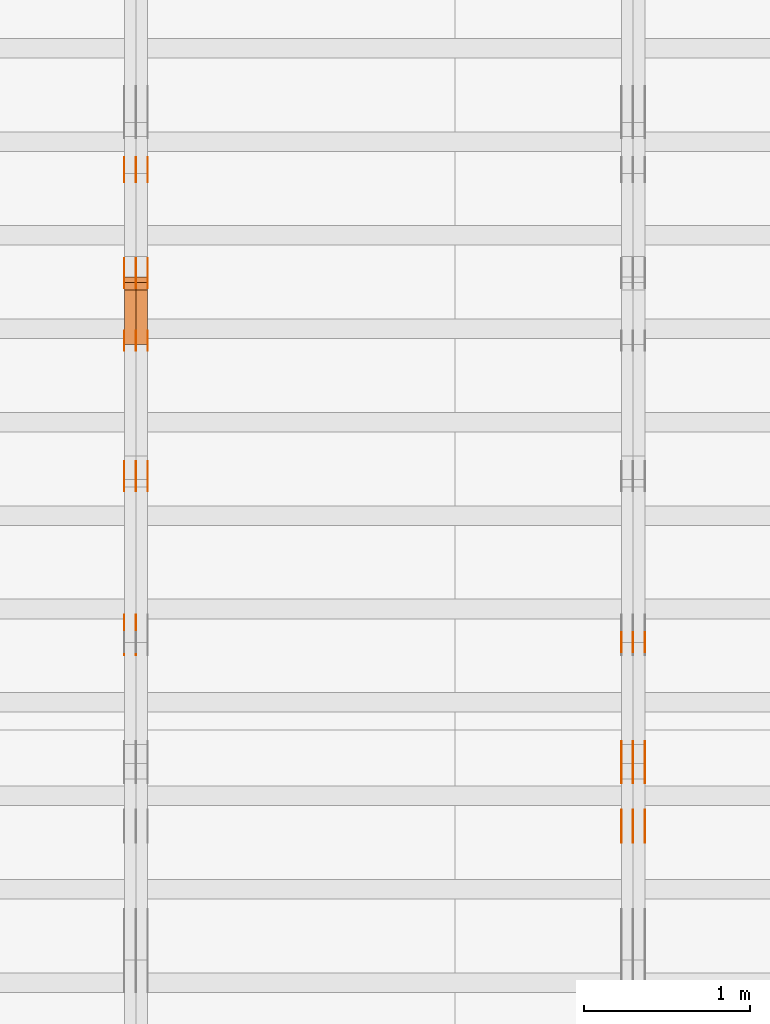
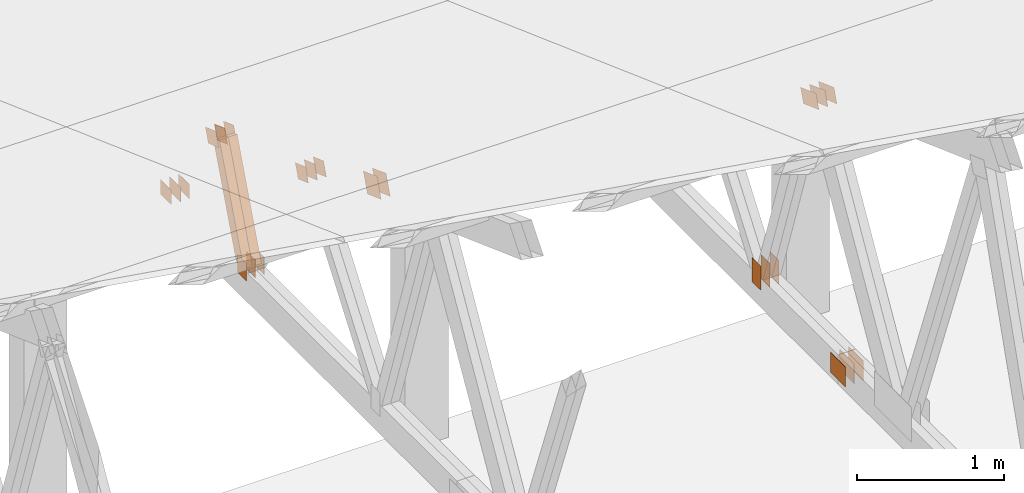
# One storey, part 131 of 189: 32 proxies.
"""IFC2X3 building model written with IfcOpenShell, lengths in millimetres."""

from ifc_helpers import new_model, entity, si_unit, converted_unit, derived_unit, direction, frame, frame_2d, origin, origin_2d_with_axis, place, context, subcontext, project, spatial, polyline, rectangle, outline, extrude, source, transform, mapped, material, type_object, type_shapes, element, save


model = new_model("IFC2X3")

# Units and contexts
model_context = context("Model", 3, precision=0.01, world=origin(), true_north=direction((6.12303176911189e-17, 1.0)))
body_context = subcontext(model_context, "Body", "Model", "MODEL_VIEW")
ifc_project = project(units=[si_unit("LENGTHUNIT", "METRE", prefix="MILLI"), si_unit("AREAUNIT", "SQUARE_METRE"), si_unit("VOLUMEUNIT", "CUBIC_METRE"), converted_unit("PLANEANGLEUNIT", "DEGREE", entity("IfcRatioMeasure", 0.0174532925199433), si_unit("PLANEANGLEUNIT", "RADIAN"), dimensions=[0, 0, 0, 0, 0, 0, 0]), si_unit("MASSUNIT", "GRAM", prefix="KILO"), derived_unit("MASSDENSITYUNIT", [(si_unit("MASSUNIT", "GRAM", prefix="KILO"), 1), (si_unit("LENGTHUNIT", "METRE"), -3)]), si_unit("TIMEUNIT", "SECOND"), si_unit("FREQUENCYUNIT", "HERTZ"), si_unit("THERMODYNAMICTEMPERATUREUNIT", "DEGREE_CELSIUS"), derived_unit("THERMALTRANSMITTANCEUNIT", [(si_unit("MASSUNIT", "GRAM", prefix="KILO"), 1), (si_unit("THERMODYNAMICTEMPERATUREUNIT", "KELVIN"), -1), (si_unit("TIMEUNIT", "SECOND"), -3)]), derived_unit("VOLUMETRICFLOWRATEUNIT", [(si_unit("LENGTHUNIT", "METRE"), 3), (si_unit("TIMEUNIT", "SECOND"), -1)]), si_unit("ELECTRICCURRENTUNIT", "AMPERE"), si_unit("ELECTRICVOLTAGEUNIT", "VOLT"), si_unit("POWERUNIT", "WATT"), si_unit("FORCEUNIT", "NEWTON"), si_unit("ILLUMINANCEUNIT", "LUX"), si_unit("LUMINOUSFLUXUNIT", "LUMEN"), si_unit("LUMINOUSINTENSITYUNIT", "CANDELA"), derived_unit("USERDEFINED", [(si_unit("MASSUNIT", "GRAM", prefix="KILO"), -1), (si_unit("LENGTHUNIT", "METRE"), -2), (si_unit("TIMEUNIT", "SECOND"), 3), (si_unit("LUMINOUSFLUXUNIT", "LUMEN"), 1)]), derived_unit("LINEARVELOCITYUNIT", [(si_unit("LENGTHUNIT", "METRE"), 1), (si_unit("TIMEUNIT", "SECOND"), -1)]), si_unit("PRESSUREUNIT", "PASCAL"), derived_unit("USERDEFINED", [(si_unit("LENGTHUNIT", "METRE"), -2), (si_unit("MASSUNIT", "GRAM", prefix="KILO"), 1), (si_unit("TIMEUNIT", "SECOND"), -2)])], contexts=[model_context])

# Site, building, storey
site_placement = place(None, origin())
site = spatial("IfcSite", under=ifc_project, at=site_placement, CompositionType="ELEMENT")
building_placement = place(site_placement, origin())
building = spatial("IfcBuilding", under=site, at=building_placement, CompositionType="ELEMENT")
storey_placement = place(building_placement, origin())
storey = spatial("IfcBuildingStorey", under=building, at=storey_placement, Name="Default", CompositionType="ELEMENT", Elevation=0.0)

# Proxies
ifc_material_1 = material(Name="IfcSurfaceStyle #153848")
building_element_proxy_type_1 = type_object("IfcBuildingElementProxyType", PredefinedType="NOTDEFINED", material=ifc_material_1)
shared_shape_1 = source(origin(), body_context, "Body", "SweptSolid", [
    extrude(outline(polyline([(-112.499846801582, -59.999986193028), (112.499924372729, -59.999986193028), (112.499888552087, 59.999986193028), (-112.499966123235, 59.999986193028), (-112.499846801582, -59.999986193028)])), frame((112.499989807712, 60.0001003787081, 0.0), z_axis=(0.0, 0.0, 1.0), x_axis=(-1.0, 0.0, 0.0)), (0.0, 0.0, 1.0), 1.3),
])
type_shapes(building_element_proxy_type_1, [shared_shape_1])
proxy_1_placement = place(building_placement, frame((27301.3, 24040.8868138992, 2049.61031693104), z_axis=(-1.0, 0.0, 0.0), x_axis=(0.0, -0.939692620785908, 0.342020143325669)))
element("IfcBuildingElementProxy", 1, at=proxy_1_placement, inside=storey, type_object=building_element_proxy_type_1, material=ifc_material_1, context=body_context, shape_type="MappedRepresentation", body=[
    mapped(shared_shape_1, transform((0.0, 0.0, 0.0), scale=1.0)),
])
ifc_material_2 = material(Name="IfcSurfaceStyle #153791")
building_element_proxy_type_2 = type_object("IfcBuildingElementProxyType", PredefinedType="NOTDEFINED", material=ifc_material_2)
shared_shape_2 = source(origin(), body_context, "Body", "SweptSolid", [
    extrude(outline(polyline([(-112.499846801582, -59.999986193028), (112.499924372729, -59.999986193028), (112.499888552087, 59.999986193028), (-112.499966123235, 59.999986193028), (-112.499846801582, -59.999986193028)])), frame((112.499989807712, 60.0001003787081, 0.0), z_axis=(0.0, 0.0, 1.0), x_axis=(-1.0, 0.0, 0.0)), (0.0, 0.0, 1.0), 1.29999999999998),
])
type_shapes(building_element_proxy_type_2, [shared_shape_2])
proxy_2_placement = place(building_placement, frame((27230.0, 24040.8868138992, 2049.61031693104), z_axis=(-1.0, 0.0, 0.0), x_axis=(0.0, -0.939692620785908, 0.342020143325669)))
element("IfcBuildingElementProxy", 2, at=proxy_2_placement, inside=storey, type_object=building_element_proxy_type_2, material=ifc_material_2, context=body_context, shape_type="MappedRepresentation", body=[
    mapped(shared_shape_2, transform((0.0, 0.0, 0.0), scale=1.0)),
])
ifc_material_3 = material(Name="IfcSurfaceStyle #153734")
building_element_proxy_type_3 = type_object("IfcBuildingElementProxyType", PredefinedType="NOTDEFINED", material=ifc_material_3)
shared_shape_3 = source(origin(), body_context, "Body", "SweptSolid", [
    extrude(outline(polyline([(-112.499846801582, -59.999986193028), (112.499924372729, -59.999986193028), (112.499888552087, 59.999986193028), (-112.499966123235, 59.999986193028), (-112.499846801582, -59.999986193028)])), frame((112.499989807712, 60.0001003787081, 0.0), z_axis=(0.0, 0.0, 1.0), x_axis=(-1.0, 0.0, 0.0)), (0.0, 0.0, 1.0), 1.29999999999998),
])
type_shapes(building_element_proxy_type_3, [shared_shape_3])
proxy_3_placement = place(building_placement, frame((27231.3, 24040.8868138992, 2049.61031693104), z_axis=(-1.0, 0.0, 0.0), x_axis=(0.0, -0.939692620785908, 0.342020143325669)))
element("IfcBuildingElementProxy", 3, at=proxy_3_placement, inside=storey, type_object=building_element_proxy_type_3, material=ifc_material_3, context=body_context, shape_type="MappedRepresentation", body=[
    mapped(shared_shape_3, transform((0.0, 0.0, 0.0), scale=1.0)),
])
ifc_material_4 = material(Name="IfcSurfaceStyle #153677")
building_element_proxy_type_4 = type_object("IfcBuildingElementProxyType", PredefinedType="NOTDEFINED", material=ifc_material_4)
shared_shape_4 = source(origin(), body_context, "Body", "SweptSolid", [
    extrude(outline(polyline([(-112.499846801582, -59.999986193028), (112.499924372729, -59.999986193028), (112.499888552087, 59.999986193028), (-112.499966123235, 59.999986193028), (-112.499846801582, -59.999986193028)])), frame((112.499989807712, 60.0001003787081, 0.0), z_axis=(0.0, 0.0, 1.0), x_axis=(-1.0, 0.0, 0.0)), (0.0, 0.0, 1.0), 1.29999999999999),
])
type_shapes(building_element_proxy_type_4, [shared_shape_4])
proxy_4_placement = place(building_placement, frame((27160.0, 24040.8868138992, 2049.61031693104), z_axis=(-1.0, 0.0, 0.0), x_axis=(0.0, -0.939692620785908, 0.342020143325669)))
element("IfcBuildingElementProxy", 4, at=proxy_4_placement, inside=storey, type_object=building_element_proxy_type_4, material=ifc_material_4, context=body_context, shape_type="MappedRepresentation", body=[
    mapped(shared_shape_4, transform((0.0, 0.0, 0.0), scale=1.0)),
])
ifc_material_5 = material(Name="IfcSurfaceStyle #153620")
building_element_proxy_type_5 = type_object("IfcBuildingElementProxyType", PredefinedType="NOTDEFINED", material=ifc_material_5)
shared_shape_5 = source(origin(), body_context, "Body", "SweptSolid", [
    extrude(rectangle(XDim=200.0, YDim=120.0, at=origin_2d_with_axis()), frame((100.0, 60.0002296775929, 0.0), z_axis=(0.0, 0.0, 1.0), x_axis=(-1.0, 0.0, 0.0)), (0.0, 0.0, 1.0), 1.3),
])
type_shapes(building_element_proxy_type_5, [shared_shape_5])
proxy_5_placement = place(building_placement, frame((27301.3, 24619.3435203224, 145.0), z_axis=(-1.0, 0.0, 0.0), x_axis=(0.0, 0.0, 1.0)))
element("IfcBuildingElementProxy", 5, at=proxy_5_placement, inside=storey, type_object=building_element_proxy_type_5, material=ifc_material_5, context=body_context, shape_type="MappedRepresentation", body=[
    mapped(shared_shape_5, transform((0.0, 0.0, 0.0), scale=1.0)),
])
ifc_material_6 = material(Name="IfcSurfaceStyle #153563")
building_element_proxy_type_6 = type_object("IfcBuildingElementProxyType", PredefinedType="NOTDEFINED", material=ifc_material_6)
shared_shape_6 = source(origin(), body_context, "Body", "SweptSolid", [
    extrude(rectangle(XDim=200.0, YDim=120.0, at=origin_2d_with_axis()), frame((100.0, 60.0002296775929, 0.0), z_axis=(0.0, 0.0, 1.0), x_axis=(-1.0, 0.0, 0.0)), (0.0, 0.0, 1.0), 1.29999999999998),
])
type_shapes(building_element_proxy_type_6, [shared_shape_6])
proxy_6_placement = place(building_placement, frame((27230.0, 24619.3435203224, 145.0), z_axis=(-1.0, 0.0, 0.0), x_axis=(0.0, 0.0, 1.0)))
element("IfcBuildingElementProxy", 6, at=proxy_6_placement, inside=storey, type_object=building_element_proxy_type_6, material=ifc_material_6, context=body_context, shape_type="MappedRepresentation", body=[
    mapped(shared_shape_6, transform((0.0, 0.0, 0.0), scale=1.0)),
])
ifc_material_7 = material(Name="IfcSurfaceStyle #153506")
building_element_proxy_type_7 = type_object("IfcBuildingElementProxyType", PredefinedType="NOTDEFINED", material=ifc_material_7)
shared_shape_7 = source(origin(), body_context, "Body", "SweptSolid", [
    extrude(rectangle(XDim=200.0, YDim=120.0, at=origin_2d_with_axis()), frame((100.0, 60.0002296775929, 0.0), z_axis=(0.0, 0.0, 1.0), x_axis=(-1.0, 0.0, 0.0)), (0.0, 0.0, 1.0), 1.29999999999998),
])
type_shapes(building_element_proxy_type_7, [shared_shape_7])
proxy_7_placement = place(building_placement, frame((27231.3, 24619.3435203224, 145.0), z_axis=(-1.0, 0.0, 0.0), x_axis=(0.0, 0.0, 1.0)))
element("IfcBuildingElementProxy", 7, at=proxy_7_placement, inside=storey, type_object=building_element_proxy_type_7, material=ifc_material_7, context=body_context, shape_type="MappedRepresentation", body=[
    mapped(shared_shape_7, transform((0.0, 0.0, 0.0), scale=1.0)),
])
ifc_material_8 = material(Name="IfcSurfaceStyle #153449")
building_element_proxy_type_8 = type_object("IfcBuildingElementProxyType", PredefinedType="NOTDEFINED", material=ifc_material_8)
shared_shape_8 = source(origin(), body_context, "Body", "SweptSolid", [
    extrude(rectangle(XDim=200.0, YDim=120.0, at=origin_2d_with_axis()), frame((100.0, 60.0002296775929, 0.0), z_axis=(0.0, 0.0, 1.0), x_axis=(-1.0, 0.0, 0.0)), (0.0, 0.0, 1.0), 1.29999999999999),
])
type_shapes(building_element_proxy_type_8, [shared_shape_8])
proxy_8_placement = place(building_placement, frame((27160.0, 24619.3435203224, 145.0), z_axis=(-1.0, 0.0, 0.0), x_axis=(0.0, 0.0, 1.0)))
element("IfcBuildingElementProxy", 8, at=proxy_8_placement, inside=storey, type_object=building_element_proxy_type_8, material=ifc_material_8, context=body_context, shape_type="MappedRepresentation", body=[
    mapped(shared_shape_8, transform((0.0, 0.0, 0.0), scale=1.0)),
])
ifc_material_9 = material(Name="IfcSurfaceStyle #149972")
building_element_proxy_type_9 = type_object("IfcBuildingElementProxyType", PredefinedType="NOTDEFINED", material=ifc_material_9)
shared_shape_9 = source(origin(), body_context, "Body", "SweptSolid", [
    extrude(rectangle(XDim=200.0, YDim=168.0, at=origin_2d_with_axis()), frame((100.0, 84.0, 0.0), z_axis=(0.0, 0.0, 1.0), x_axis=(-1.0, 0.0, 0.0)), (0.0, 0.0, 1.0), 1.3),
])
type_shapes(building_element_proxy_type_9, [shared_shape_9])
proxy_9_placement = place(building_placement, frame((27301.3, 23470.0, 206.5), z_axis=(-1.0, 0.0, 0.0), x_axis=(0.0, 1.0, 0.0)))
element("IfcBuildingElementProxy", 9, at=proxy_9_placement, inside=storey, type_object=building_element_proxy_type_9, material=ifc_material_9, context=body_context, shape_type="MappedRepresentation", body=[
    mapped(shared_shape_9, transform((0.0, 0.0, 0.0), scale=1.0)),
])
ifc_material_10 = material(Name="IfcSurfaceStyle #149915")
building_element_proxy_type_10 = type_object("IfcBuildingElementProxyType", PredefinedType="NOTDEFINED", material=ifc_material_10)
shared_shape_10 = source(origin(), body_context, "Body", "SweptSolid", [
    extrude(rectangle(XDim=200.0, YDim=168.0, at=origin_2d_with_axis()), frame((100.0, 84.0, 0.0), z_axis=(0.0, 0.0, 1.0), x_axis=(-1.0, 0.0, 0.0)), (0.0, 0.0, 1.0), 1.29999999999998),
])
type_shapes(building_element_proxy_type_10, [shared_shape_10])
proxy_10_placement = place(building_placement, frame((27230.0, 23470.0, 206.5), z_axis=(-1.0, 0.0, 0.0), x_axis=(0.0, 1.0, 0.0)))
element("IfcBuildingElementProxy", 10, at=proxy_10_placement, inside=storey, type_object=building_element_proxy_type_10, material=ifc_material_10, context=body_context, shape_type="MappedRepresentation", body=[
    mapped(shared_shape_10, transform((0.0, 0.0, 0.0), scale=1.0)),
])
ifc_material_11 = material(Name="IfcSurfaceStyle #149858")
building_element_proxy_type_11 = type_object("IfcBuildingElementProxyType", PredefinedType="NOTDEFINED", material=ifc_material_11)
shared_shape_11 = source(origin(), body_context, "Body", "SweptSolid", [
    extrude(rectangle(XDim=200.0, YDim=168.0, at=origin_2d_with_axis()), frame((100.0, 84.0, 0.0), z_axis=(0.0, 0.0, 1.0), x_axis=(-1.0, 0.0, 0.0)), (0.0, 0.0, 1.0), 1.29999999999998),
])
type_shapes(building_element_proxy_type_11, [shared_shape_11])
proxy_11_placement = place(building_placement, frame((27231.3, 23470.0, 206.5), z_axis=(-1.0, 0.0, 0.0), x_axis=(0.0, 1.0, 0.0)))
element("IfcBuildingElementProxy", 11, at=proxy_11_placement, inside=storey, type_object=building_element_proxy_type_11, material=ifc_material_11, context=body_context, shape_type="MappedRepresentation", body=[
    mapped(shared_shape_11, transform((0.0, 0.0, 0.0), scale=1.0)),
])
ifc_material_12 = material(Name="IfcSurfaceStyle #149801")
building_element_proxy_type_12 = type_object("IfcBuildingElementProxyType", PredefinedType="NOTDEFINED", material=ifc_material_12)
shared_shape_12 = source(origin(), body_context, "Body", "SweptSolid", [
    extrude(rectangle(XDim=200.0, YDim=168.0, at=origin_2d_with_axis()), frame((100.0, 84.0, 0.0), z_axis=(0.0, 0.0, 1.0), x_axis=(-1.0, 0.0, 0.0)), (0.0, 0.0, 1.0), 1.29999999999999),
])
type_shapes(building_element_proxy_type_12, [shared_shape_12])
proxy_12_placement = place(building_placement, frame((27160.0, 23470.0, 206.5), z_axis=(-1.0, 0.0, 0.0), x_axis=(0.0, 1.0, 0.0)))
element("IfcBuildingElementProxy", 12, at=proxy_12_placement, inside=storey, type_object=building_element_proxy_type_12, material=ifc_material_12, context=body_context, shape_type="MappedRepresentation", body=[
    mapped(shared_shape_12, transform((0.0, 0.0, 0.0), scale=1.0)),
])
ifc_material_13 = material(Name="IfcSurfaceStyle #137146")
building_element_proxy_type_13 = type_object("IfcBuildingElementProxyType", PredefinedType="NOTDEFINED", material=ifc_material_13)
shared_shape_13 = source(origin(), body_context, "Body", "SweptSolid", [
    extrude(outline(polyline([(-74.9999475298494, -60.0), (75.0000042257432, -60.0), (74.9999684051025, 60.0), (-75.0000251009963, 60.0), (-74.9999475298494, -60.0)])), frame((75.0000607644577, 60.0000865490217, 0.0), z_axis=(0.0, 0.0, 1.0), x_axis=(-1.0, 0.0, 0.0)), (0.0, 0.0, 1.0), 1.3),
])
type_shapes(building_element_proxy_type_13, [shared_shape_13])
proxy_13_placement = place(building_placement, frame((24301.3, 25732.0586805394, 1446.84420669249), z_axis=(-1.0, 0.0, 0.0), x_axis=(0.0, -0.939692620785908, 0.342020143325669)))
element("IfcBuildingElementProxy", 13, at=proxy_13_placement, inside=storey, type_object=building_element_proxy_type_13, material=ifc_material_13, context=body_context, shape_type="MappedRepresentation", body=[
    mapped(shared_shape_13, transform((0.0, 0.0, 0.0), scale=1.0)),
])
ifc_material_14 = material(Name="IfcSurfaceStyle #137089")
building_element_proxy_type_14 = type_object("IfcBuildingElementProxyType", PredefinedType="NOTDEFINED", material=ifc_material_14)
shared_shape_14 = source(origin(), body_context, "Body", "SweptSolid", [
    extrude(outline(polyline([(-74.9999475298494, -60.0), (75.0000042257432, -60.0), (74.9999684051025, 60.0), (-75.0000251009963, 60.0), (-74.9999475298494, -60.0)])), frame((75.0000607644577, 60.0000865490217, 0.0), z_axis=(0.0, 0.0, 1.0), x_axis=(-1.0, 0.0, 0.0)), (0.0, 0.0, 1.0), 1.29999999999999),
])
type_shapes(building_element_proxy_type_14, [shared_shape_14])
proxy_14_placement = place(building_placement, frame((24230.0, 25732.0586805394, 1446.84420669249), z_axis=(-1.0, 0.0, 0.0), x_axis=(0.0, -0.939692620785908, 0.342020143325669)))
element("IfcBuildingElementProxy", 14, at=proxy_14_placement, inside=storey, type_object=building_element_proxy_type_14, material=ifc_material_14, context=body_context, shape_type="MappedRepresentation", body=[
    mapped(shared_shape_14, transform((0.0, 0.0, 0.0), scale=1.0)),
])
ifc_material_15 = material(Name="IfcSurfaceStyle #137032")
building_element_proxy_type_15 = type_object("IfcBuildingElementProxyType", PredefinedType="NOTDEFINED", material=ifc_material_15)
shared_shape_15 = source(origin(), body_context, "Body", "SweptSolid", [
    extrude(outline(polyline([(-74.9999475298494, -60.0), (75.0000042257432, -60.0), (74.9999684051025, 60.0), (-75.0000251009963, 60.0), (-74.9999475298494, -60.0)])), frame((75.0000607644577, 60.0000865490217, 0.0), z_axis=(0.0, 0.0, 1.0), x_axis=(-1.0, 0.0, 0.0)), (0.0, 0.0, 1.0), 1.29999999999999),
])
type_shapes(building_element_proxy_type_15, [shared_shape_15])
proxy_15_placement = place(building_placement, frame((24231.3, 25732.0586805394, 1446.84420669249), z_axis=(-1.0, 0.0, 0.0), x_axis=(0.0, -0.939692620785908, 0.342020143325669)))
element("IfcBuildingElementProxy", 15, at=proxy_15_placement, inside=storey, type_object=building_element_proxy_type_15, material=ifc_material_15, context=body_context, shape_type="MappedRepresentation", body=[
    mapped(shared_shape_15, transform((0.0, 0.0, 0.0), scale=1.0)),
])
ifc_material_16 = material(Name="IfcSurfaceStyle #136975")
building_element_proxy_type_16 = type_object("IfcBuildingElementProxyType", PredefinedType="NOTDEFINED", material=ifc_material_16)
shared_shape_16 = source(origin(), body_context, "Body", "SweptSolid", [
    extrude(outline(polyline([(-74.9999475298494, -60.0), (75.0000042257432, -60.0), (74.9999684051025, 60.0), (-75.0000251009963, 60.0), (-74.9999475298494, -60.0)])), frame((75.0000607644577, 60.0000865490217, 0.0), z_axis=(0.0, 0.0, 1.0), x_axis=(-1.0, 0.0, 0.0)), (0.0, 0.0, 1.0), 1.29999999999999),
])
type_shapes(building_element_proxy_type_16, [shared_shape_16])
proxy_16_placement = place(building_placement, frame((24160.0, 25732.0586805394, 1446.84420669249), z_axis=(-1.0, 0.0, 0.0), x_axis=(0.0, -0.939692620785908, 0.342020143325669)))
element("IfcBuildingElementProxy", 16, at=proxy_16_placement, inside=storey, type_object=building_element_proxy_type_16, material=ifc_material_16, context=body_context, shape_type="MappedRepresentation", body=[
    mapped(shared_shape_16, transform((0.0, 0.0, 0.0), scale=1.0)),
])
ifc_material_17 = material(Name="IfcSurfaceStyle #136918")
building_element_proxy_type_17 = type_object("IfcBuildingElementProxyType", PredefinedType="NOTDEFINED", material=ifc_material_17)
shared_shape_17 = source(origin(), body_context, "Body", "SweptSolid", [
    extrude(rectangle(XDim=150.0, YDim=120.0, at=frame_2d((-7.105427357601e-15, 0.0), x_axis=(1.0, 0.0))), frame((75.0, 60.0, 0.0), z_axis=(0.0, 0.0, 1.0), x_axis=(-1.0, 0.0, 0.0)), (0.0, 0.0, 1.0), 1.3),
])
type_shapes(building_element_proxy_type_17, [shared_shape_17])
proxy_17_placement = place(building_placement, frame((24301.3, 26439.0083007813, 170.0), z_axis=(-1.0, 0.0, 0.0), x_axis=(0.0, 0.0, 1.0)))
element("IfcBuildingElementProxy", 17, at=proxy_17_placement, inside=storey, type_object=building_element_proxy_type_17, material=ifc_material_17, context=body_context, shape_type="MappedRepresentation", body=[
    mapped(shared_shape_17, transform((0.0, 0.0, 0.0), scale=1.0)),
])
ifc_material_18 = material(Name="IfcSurfaceStyle #136861")
building_element_proxy_type_18 = type_object("IfcBuildingElementProxyType", PredefinedType="NOTDEFINED", material=ifc_material_18)
shared_shape_18 = source(origin(), body_context, "Body", "SweptSolid", [
    extrude(rectangle(XDim=150.0, YDim=120.0, at=frame_2d((-7.105427357601e-15, 0.0), x_axis=(1.0, 0.0))), frame((75.0, 60.0, 0.0), z_axis=(0.0, 0.0, 1.0), x_axis=(-1.0, 0.0, 0.0)), (0.0, 0.0, 1.0), 1.29999999999999),
])
type_shapes(building_element_proxy_type_18, [shared_shape_18])
proxy_18_placement = place(building_placement, frame((24230.0, 26439.0083007813, 170.0), z_axis=(-1.0, 0.0, 0.0), x_axis=(0.0, 0.0, 1.0)))
element("IfcBuildingElementProxy", 18, at=proxy_18_placement, inside=storey, type_object=building_element_proxy_type_18, material=ifc_material_18, context=body_context, shape_type="MappedRepresentation", body=[
    mapped(shared_shape_18, transform((0.0, 0.0, 0.0), scale=1.0)),
])
ifc_material_19 = material(Name="IfcSurfaceStyle #136804")
building_element_proxy_type_19 = type_object("IfcBuildingElementProxyType", PredefinedType="NOTDEFINED", material=ifc_material_19)
shared_shape_19 = source(origin(), body_context, "Body", "SweptSolid", [
    extrude(rectangle(XDim=150.0, YDim=120.0, at=frame_2d((-7.105427357601e-15, 0.0), x_axis=(1.0, 0.0))), frame((75.0, 60.0, 0.0), z_axis=(0.0, 0.0, 1.0), x_axis=(-1.0, 0.0, 0.0)), (0.0, 0.0, 1.0), 1.29999999999999),
])
type_shapes(building_element_proxy_type_19, [shared_shape_19])
proxy_19_placement = place(building_placement, frame((24231.3, 26439.0083007813, 170.0), z_axis=(-1.0, 0.0, 0.0), x_axis=(0.0, 0.0, 1.0)))
element("IfcBuildingElementProxy", 19, at=proxy_19_placement, inside=storey, type_object=building_element_proxy_type_19, material=ifc_material_19, context=body_context, shape_type="MappedRepresentation", body=[
    mapped(shared_shape_19, transform((0.0, 0.0, 0.0), scale=1.0)),
])
ifc_material_20 = material(Name="IfcSurfaceStyle #136747")
building_element_proxy_type_20 = type_object("IfcBuildingElementProxyType", PredefinedType="NOTDEFINED", material=ifc_material_20)
shared_shape_20 = source(origin(), body_context, "Body", "SweptSolid", [
    extrude(rectangle(XDim=150.0, YDim=120.0, at=frame_2d((-7.105427357601e-15, 0.0), x_axis=(1.0, 0.0))), frame((75.0, 60.0, 0.0), z_axis=(0.0, 0.0, 1.0), x_axis=(-1.0, 0.0, 0.0)), (0.0, 0.0, 1.0), 1.29999999999999),
])
type_shapes(building_element_proxy_type_20, [shared_shape_20])
proxy_20_placement = place(building_placement, frame((24160.0, 26439.0083007813, 170.0), z_axis=(-1.0, 0.0, 0.0), x_axis=(0.0, 0.0, 1.0)))
element("IfcBuildingElementProxy", 20, at=proxy_20_placement, inside=storey, type_object=building_element_proxy_type_20, material=ifc_material_20, context=body_context, shape_type="MappedRepresentation", body=[
    mapped(shared_shape_20, transform((0.0, 0.0, 0.0), scale=1.0)),
])
ifc_material_21 = material(Name="IfcSurfaceStyle #136234")
building_element_proxy_type_21 = type_object("IfcBuildingElementProxyType", PredefinedType="NOTDEFINED", material=ifc_material_21)
shared_shape_21 = source(origin(), body_context, "Body", "SweptSolid", [
    extrude(outline(polyline([(-74.9999684051023, -60.0), (75.0000251009964, -60.0), (74.9999475298495, 60.0), (-75.0000042257435, 60.0), (-74.9999684051023, -60.0)])), frame((75.0000251009964, 60.0000006265238, 0.0), z_axis=(0.0, 0.0, 1.0), x_axis=(-1.0, 0.0, 0.0)), (0.0, 0.0, 1.0), 1.3),
])
type_shapes(building_element_proxy_type_21, [shared_shape_21])
proxy_21_placement = place(building_placement, frame((24301.3, 26956.490053282, 1001.18769055967), z_axis=(-1.0, 0.0, 0.0), x_axis=(0.0, -0.939692620785908, 0.342020143325669)))
element("IfcBuildingElementProxy", 21, at=proxy_21_placement, inside=storey, type_object=building_element_proxy_type_21, material=ifc_material_21, context=body_context, shape_type="MappedRepresentation", body=[
    mapped(shared_shape_21, transform((0.0, 0.0, 0.0), scale=1.0)),
])
ifc_material_22 = material(Name="IfcSurfaceStyle #136177")
building_element_proxy_type_22 = type_object("IfcBuildingElementProxyType", PredefinedType="NOTDEFINED", material=ifc_material_22)
shared_shape_22 = source(origin(), body_context, "Body", "SweptSolid", [
    extrude(outline(polyline([(-74.9999684051023, -60.0), (75.0000251009964, -60.0), (74.9999475298495, 60.0), (-75.0000042257435, 60.0), (-74.9999684051023, -60.0)])), frame((75.0000251009964, 60.0000006265238, 0.0), z_axis=(0.0, 0.0, 1.0), x_axis=(-1.0, 0.0, 0.0)), (0.0, 0.0, 1.0), 1.29999999999999),
])
type_shapes(building_element_proxy_type_22, [shared_shape_22])
proxy_22_placement = place(building_placement, frame((24230.0, 26956.490053282, 1001.18769055967), z_axis=(-1.0, 0.0, 0.0), x_axis=(0.0, -0.939692620785908, 0.342020143325669)))
element("IfcBuildingElementProxy", 22, at=proxy_22_placement, inside=storey, type_object=building_element_proxy_type_22, material=ifc_material_22, context=body_context, shape_type="MappedRepresentation", body=[
    mapped(shared_shape_22, transform((0.0, 0.0, 0.0), scale=1.0)),
])
ifc_material_23 = material(Name="IfcSurfaceStyle #136120")
building_element_proxy_type_23 = type_object("IfcBuildingElementProxyType", PredefinedType="NOTDEFINED", material=ifc_material_23)
shared_shape_23 = source(origin(), body_context, "Body", "SweptSolid", [
    extrude(outline(polyline([(-74.9999684051023, -60.0), (75.0000251009964, -60.0), (74.9999475298495, 60.0), (-75.0000042257435, 60.0), (-74.9999684051023, -60.0)])), frame((75.0000251009964, 60.0000006265238, 0.0), z_axis=(0.0, 0.0, 1.0), x_axis=(-1.0, 0.0, 0.0)), (0.0, 0.0, 1.0), 1.29999999999999),
])
type_shapes(building_element_proxy_type_23, [shared_shape_23])
proxy_23_placement = place(building_placement, frame((24231.3, 26956.490053282, 1001.18769055967), z_axis=(-1.0, 0.0, 0.0), x_axis=(0.0, -0.939692620785908, 0.342020143325669)))
element("IfcBuildingElementProxy", 23, at=proxy_23_placement, inside=storey, type_object=building_element_proxy_type_23, material=ifc_material_23, context=body_context, shape_type="MappedRepresentation", body=[
    mapped(shared_shape_23, transform((0.0, 0.0, 0.0), scale=1.0)),
])
ifc_material_24 = material(Name="IfcSurfaceStyle #136063")
building_element_proxy_type_24 = type_object("IfcBuildingElementProxyType", PredefinedType="NOTDEFINED", material=ifc_material_24)
shared_shape_24 = source(origin(), body_context, "Body", "SweptSolid", [
    extrude(outline(polyline([(-74.9999684051023, -60.0), (75.0000251009964, -60.0), (74.9999475298495, 60.0), (-75.0000042257435, 60.0), (-74.9999684051023, -60.0)])), frame((75.0000251009964, 60.0000006265238, 0.0), z_axis=(0.0, 0.0, 1.0), x_axis=(-1.0, 0.0, 0.0)), (0.0, 0.0, 1.0), 1.29999999999999),
])
type_shapes(building_element_proxy_type_24, [shared_shape_24])
proxy_24_placement = place(building_placement, frame((24160.0, 26956.490053282, 1001.18769055967), z_axis=(-1.0, 0.0, 0.0), x_axis=(0.0, -0.939692620785908, 0.342020143325669)))
element("IfcBuildingElementProxy", 24, at=proxy_24_placement, inside=storey, type_object=building_element_proxy_type_24, material=ifc_material_24, context=body_context, shape_type="MappedRepresentation", body=[
    mapped(shared_shape_24, transform((0.0, 0.0, 0.0), scale=1.0)),
])
ifc_material_25 = material(Name="IfcSurfaceStyle #136006")
building_element_proxy_type_25 = type_object("IfcBuildingElementProxyType", PredefinedType="NOTDEFINED", material=ifc_material_25)
shared_shape_25 = source(origin(), body_context, "Body", "SweptSolid", [
    extrude(rectangle(XDim=150.0, YDim=120.0, at=origin_2d_with_axis()), frame((75.0, 60.0, 0.0), z_axis=(0.0, 0.0, 1.0), x_axis=(-1.0, 0.0, 0.0)), (0.0, 0.0, 1.0), 1.3),
])
type_shapes(building_element_proxy_type_25, [shared_shape_25])
proxy_25_placement = place(building_placement, frame((24301.3, 27607.3129882813, 185.0), z_axis=(-1.0, 0.0, 0.0), x_axis=(0.0, -1.0, 0.0)))
element("IfcBuildingElementProxy", 25, at=proxy_25_placement, inside=storey, type_object=building_element_proxy_type_25, material=ifc_material_25, context=body_context, shape_type="MappedRepresentation", body=[
    mapped(shared_shape_25, transform((0.0, 0.0, 0.0), scale=1.0)),
])
ifc_material_26 = material(Name="IfcSurfaceStyle #135949")
building_element_proxy_type_26 = type_object("IfcBuildingElementProxyType", PredefinedType="NOTDEFINED", material=ifc_material_26)
shared_shape_26 = source(origin(), body_context, "Body", "SweptSolid", [
    extrude(rectangle(XDim=150.0, YDim=120.0, at=origin_2d_with_axis()), frame((75.0, 60.0, 0.0), z_axis=(0.0, 0.0, 1.0), x_axis=(-1.0, 0.0, 0.0)), (0.0, 0.0, 1.0), 1.29999999999999),
])
type_shapes(building_element_proxy_type_26, [shared_shape_26])
proxy_26_placement = place(building_placement, frame((24230.0, 27607.3129882813, 185.0), z_axis=(-1.0, 0.0, 0.0), x_axis=(0.0, -1.0, 0.0)))
element("IfcBuildingElementProxy", 26, at=proxy_26_placement, inside=storey, type_object=building_element_proxy_type_26, material=ifc_material_26, context=body_context, shape_type="MappedRepresentation", body=[
    mapped(shared_shape_26, transform((0.0, 0.0, 0.0), scale=1.0)),
])
ifc_material_27 = material(Name="IfcSurfaceStyle #135892")
building_element_proxy_type_27 = type_object("IfcBuildingElementProxyType", PredefinedType="NOTDEFINED", material=ifc_material_27)
shared_shape_27 = source(origin(), body_context, "Body", "SweptSolid", [
    extrude(rectangle(XDim=150.0, YDim=120.0, at=origin_2d_with_axis()), frame((75.0, 60.0, 0.0), z_axis=(0.0, 0.0, 1.0), x_axis=(-1.0, 0.0, 0.0)), (0.0, 0.0, 1.0), 1.29999999999999),
])
type_shapes(building_element_proxy_type_27, [shared_shape_27])
proxy_27_placement = place(building_placement, frame((24231.3, 27607.3129882813, 185.0), z_axis=(-1.0, 0.0, 0.0), x_axis=(0.0, -1.0, 0.0)))
element("IfcBuildingElementProxy", 27, at=proxy_27_placement, inside=storey, type_object=building_element_proxy_type_27, material=ifc_material_27, context=body_context, shape_type="MappedRepresentation", body=[
    mapped(shared_shape_27, transform((0.0, 0.0, 0.0), scale=1.0)),
])
ifc_material_28 = material(Name="IfcSurfaceStyle #135835")
building_element_proxy_type_28 = type_object("IfcBuildingElementProxyType", PredefinedType="NOTDEFINED", material=ifc_material_28)
shared_shape_28 = source(origin(), body_context, "Body", "SweptSolid", [
    extrude(rectangle(XDim=150.0, YDim=120.0, at=origin_2d_with_axis()), frame((75.0, 60.0, 0.0), z_axis=(0.0, 0.0, 1.0), x_axis=(-1.0, 0.0, 0.0)), (0.0, 0.0, 1.0), 1.29999999999999),
])
type_shapes(building_element_proxy_type_28, [shared_shape_28])
proxy_28_placement = place(building_placement, frame((24160.0, 27607.3129882813, 185.0), z_axis=(-1.0, 0.0, 0.0), x_axis=(0.0, -1.0, 0.0)))
element("IfcBuildingElementProxy", 28, at=proxy_28_placement, inside=storey, type_object=building_element_proxy_type_28, material=ifc_material_28, context=body_context, shape_type="MappedRepresentation", body=[
    mapped(shared_shape_28, transform((0.0, 0.0, 0.0), scale=1.0)),
])
ifc_material_29 = material(Name="IfcSurfaceStyle #131908")
building_element_proxy_type_29 = type_object("IfcBuildingElementProxyType", PredefinedType="NOTDEFINED", material=ifc_material_29)
shared_shape_29 = source(origin(), body_context, "Body", "SweptSolid", [
    extrude(outline(polyline([(-99.9999065788418, -84.0000755647729), (99.9999734279406, -84.0000755647729), (99.9999483293475, 84.000075564773), (-100.000015178446, 84.000075564773), (-99.9999065788418, -84.0000755647729)])), frame((100.000157783747, 84.0001144608011, 0.0), z_axis=(0.0, 0.0, 1.0), x_axis=(-1.0, 0.0, 0.0)), (0.0, 0.0, 1.0), 1.29999999999998),
])
type_shapes(building_element_proxy_type_29, [shared_shape_29])
proxy_29_placement = place(building_placement, frame((24231.3, 24788.4767593228, 1895.10136879206), z_axis=(-1.0, 0.0, 0.0), x_axis=(0.0, -0.939692620785908, 0.342020143325669)))
element("IfcBuildingElementProxy", 29, at=proxy_29_placement, inside=storey, type_object=building_element_proxy_type_29, material=ifc_material_29, context=body_context, shape_type="MappedRepresentation", body=[
    mapped(shared_shape_29, transform((0.0, 0.0, 0.0), scale=1.0)),
])
ifc_material_30 = material(Name="IfcSurfaceStyle #131851")
building_element_proxy_type_30 = type_object("IfcBuildingElementProxyType", PredefinedType="NOTDEFINED", material=ifc_material_30)
shared_shape_30 = source(origin(), body_context, "Body", "SweptSolid", [
    extrude(outline(polyline([(-99.9999065788418, -84.0000755647729), (99.9999734279406, -84.0000755647729), (99.9999483293475, 84.000075564773), (-100.000015178446, 84.000075564773), (-99.9999065788418, -84.0000755647729)])), frame((100.000157783747, 84.0001144608011, 0.0), z_axis=(0.0, 0.0, 1.0), x_axis=(-1.0, 0.0, 0.0)), (0.0, 0.0, 1.0), 1.29999999999999),
])
type_shapes(building_element_proxy_type_30, [shared_shape_30])
proxy_30_placement = place(building_placement, frame((24160.0, 24788.4767593228, 1895.10136879206), z_axis=(-1.0, 0.0, 0.0), x_axis=(0.0, -0.939692620785908, 0.342020143325669)))
element("IfcBuildingElementProxy", 30, at=proxy_30_placement, inside=storey, type_object=building_element_proxy_type_30, material=ifc_material_30, context=body_context, shape_type="MappedRepresentation", body=[
    mapped(shared_shape_30, transform((0.0, 0.0, 0.0), scale=1.0)),
])
ifc_material_31 = material(Name="IfcSurfaceStyle #128758")
building_element_proxy_type_31 = type_object("IfcBuildingElementProxyType", Name="T1-W14 128756", PredefinedType="NOTDEFINED", material=ifc_material_31)
shared_shape_31 = source(origin(), body_context, "Body", "SweptSolid", [
    extrude(outline(polyline([(-561.981237417233, -47.499947472121), (373.092610496013, -47.499947472121), (373.679602940405, -4.61719047935016e-05), (341.277449358876, 47.4999705580734), (-526.068425378061, 47.4999705580734), (-561.981237417233, -47.499947472121)])), frame((373.679632439416, 47.500120814091, 0.0), z_axis=(0.0, 0.0, 1.0), x_axis=(-1.0, 0.0, 0.0)), (0.0, 0.0, 1.0), 69.9999999999999),
])
type_shapes(building_element_proxy_type_31, [shared_shape_31])
proxy_31_placement = place(building_placement, frame((24300.0, 26895.4809555667, 1086.61918844835), z_axis=(-1.0, 0.0, 0.0), x_axis=(0.0, -0.353606472447933, -0.935394281916951)))
element("IfcBuildingElementProxy", 31, at=proxy_31_placement, inside=storey, type_object=building_element_proxy_type_31, material=ifc_material_31, Name="T1-W14", context=body_context, shape_type="MappedRepresentation", body=[
    mapped(shared_shape_31, transform((0.0, 0.0, 0.0), scale=1.0)),
])
ifc_material_32 = material(Name="IfcSurfaceStyle #128692")
building_element_proxy_type_32 = type_object("IfcBuildingElementProxyType", Name="T1-W14 128690", PredefinedType="NOTDEFINED", material=ifc_material_32)
shared_shape_32 = source(origin(), body_context, "Body", "SweptSolid", [
    extrude(outline(polyline([(-561.981237417233, -47.499947472121), (373.092610496013, -47.499947472121), (373.679602940405, -4.61719047935016e-05), (341.277449358876, 47.4999705580734), (-526.068425378061, 47.4999705580734), (-561.981237417233, -47.499947472121)])), frame((373.679632439416, 47.500120814091, 0.0), z_axis=(0.0, 0.0, 1.0), x_axis=(-1.0, 0.0, 0.0)), (0.0, 0.0, 1.0), 69.9999999999999),
])
type_shapes(building_element_proxy_type_32, [shared_shape_32])
proxy_32_placement = place(building_placement, frame((24230.0, 26895.4809555667, 1086.61918844835), z_axis=(-1.0, 0.0, 0.0), x_axis=(0.0, -0.353606472447933, -0.935394281916951)))
element("IfcBuildingElementProxy", 32, at=proxy_32_placement, inside=storey, type_object=building_element_proxy_type_32, material=ifc_material_32, Name="T1-W14", context=body_context, shape_type="MappedRepresentation", body=[
    mapped(shared_shape_32, transform((0.0, 0.0, 0.0), scale=1.0)),
])

save(model, "model.ifc")
